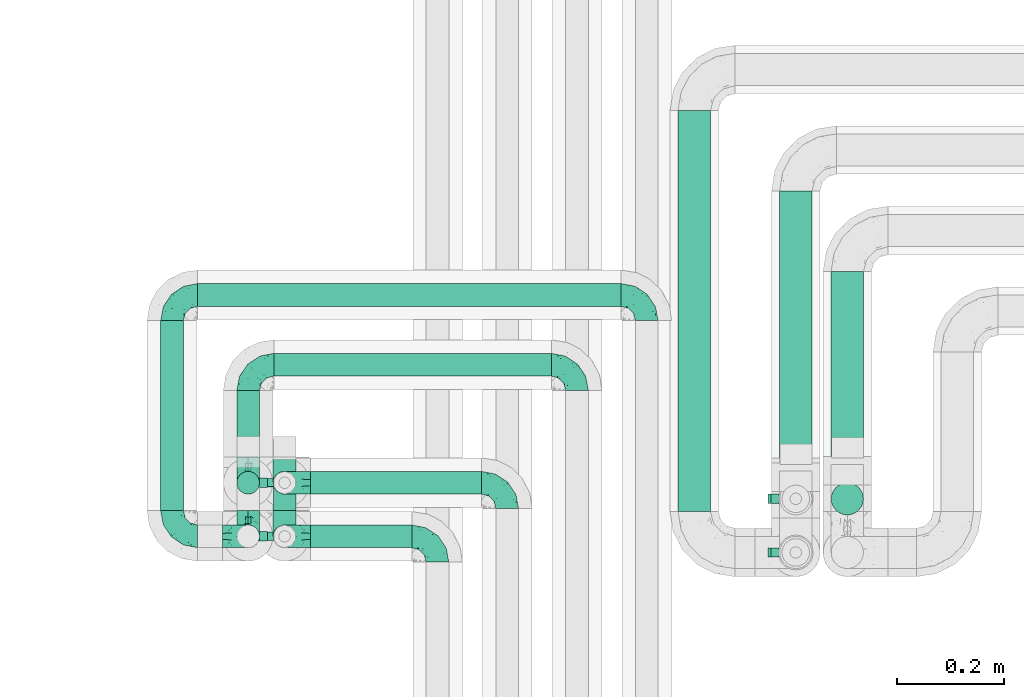
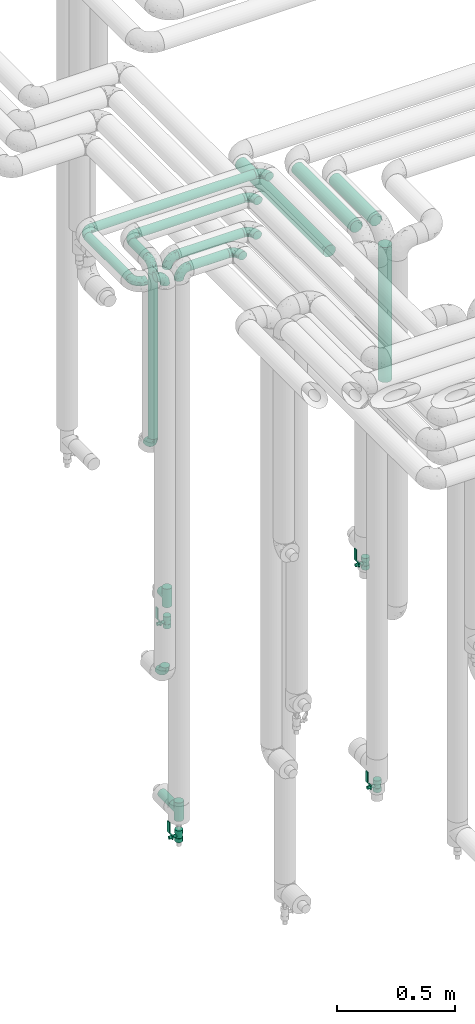
# One storey, part 632 of 827: 15 flow fittings, 12 flow segments, 4 flow controllers.
"""IFC2X3 building model written with IfcOpenShell, lengths in millimetres."""

from ifc_helpers import new_model, entity, si_unit, converted_unit, derived_unit, direction, frame, origin, origin_2d_with_axis, place, context, subcontext, project, spatial, polyline, circle, outline, extrude, faceted_brep, source, transform, mapped, material, material_list, type_object, type_shapes, element, save


model = new_model("IFC2X3")

# Units and contexts
model_context = context("Model", 3, precision=0.01, world=origin(), true_north=direction((6.12303176911189e-17, 1.0)))
body_context = subcontext(model_context, "Body", "Model", "MODEL_VIEW")
ifc_project = project(units=[si_unit("LENGTHUNIT", "METRE", prefix="MILLI"), si_unit("AREAUNIT", "SQUARE_METRE"), si_unit("VOLUMEUNIT", "CUBIC_METRE"), converted_unit("PLANEANGLEUNIT", "DEGREE", entity("IfcRatioMeasure", 0.0174532925199433), si_unit("PLANEANGLEUNIT", "RADIAN"), dimensions=[0, 0, 0, 0, 0, 0, 0]), si_unit("MASSUNIT", "GRAM", prefix="KILO"), derived_unit("MASSDENSITYUNIT", [(si_unit("MASSUNIT", "GRAM", prefix="KILO"), 1), (si_unit("LENGTHUNIT", "METRE"), -3)]), derived_unit("MOMENTOFINERTIAUNIT", [(si_unit("LENGTHUNIT", "METRE"), 4)]), si_unit("TIMEUNIT", "SECOND"), si_unit("FREQUENCYUNIT", "HERTZ"), si_unit("THERMODYNAMICTEMPERATUREUNIT", "DEGREE_CELSIUS"), derived_unit("THERMALTRANSMITTANCEUNIT", [(si_unit("MASSUNIT", "GRAM", prefix="KILO"), 1), (si_unit("THERMODYNAMICTEMPERATUREUNIT", "KELVIN"), -1), (si_unit("TIMEUNIT", "SECOND"), -3)]), derived_unit("VOLUMETRICFLOWRATEUNIT", [(si_unit("LENGTHUNIT", "METRE"), 3), (si_unit("TIMEUNIT", "SECOND"), -1)]), derived_unit("MASSFLOWRATEUNIT", [(si_unit("MASSUNIT", "GRAM", prefix="KILO"), 1), (si_unit("TIMEUNIT", "SECOND"), -1)]), derived_unit("ROTATIONALFREQUENCYUNIT", [(si_unit("TIMEUNIT", "SECOND"), -1)]), si_unit("ELECTRICCURRENTUNIT", "AMPERE"), si_unit("ELECTRICVOLTAGEUNIT", "VOLT"), si_unit("POWERUNIT", "WATT"), si_unit("FORCEUNIT", "NEWTON", prefix="KILO"), si_unit("ILLUMINANCEUNIT", "LUX"), si_unit("LUMINOUSFLUXUNIT", "LUMEN"), si_unit("LUMINOUSINTENSITYUNIT", "CANDELA"), derived_unit("USERDEFINED", [(si_unit("MASSUNIT", "GRAM", prefix="KILO"), -1), (si_unit("LENGTHUNIT", "METRE"), -2), (si_unit("TIMEUNIT", "SECOND"), 3), (si_unit("LUMINOUSFLUXUNIT", "LUMEN"), 1)]), derived_unit("LINEARVELOCITYUNIT", [(si_unit("LENGTHUNIT", "METRE"), 1), (si_unit("TIMEUNIT", "SECOND"), -1)]), si_unit("PRESSUREUNIT", "PASCAL"), derived_unit("USERDEFINED", [(si_unit("LENGTHUNIT", "METRE"), -2), (si_unit("MASSUNIT", "GRAM", prefix="KILO"), 1), (si_unit("TIMEUNIT", "SECOND"), -2)]), derived_unit("LINEARFORCEUNIT", [(si_unit("MASSUNIT", "GRAM", prefix="KILO"), 1), (si_unit("LENGTHUNIT", "METRE"), 1), (si_unit("TIMEUNIT", "SECOND"), -2), (si_unit("LENGTHUNIT", "METRE"), -1)]), derived_unit("PLANARFORCEUNIT", [(si_unit("MASSUNIT", "GRAM", prefix="KILO"), 1), (si_unit("LENGTHUNIT", "METRE"), 1), (si_unit("TIMEUNIT", "SECOND"), -2), (si_unit("LENGTHUNIT", "METRE"), -2)])], contexts=[model_context])

# Site, building, storey
site_placement = place(None, origin())
site = spatial("IfcSite", under=ifc_project, at=site_placement, CompositionType="ELEMENT")
building_placement = place(site_placement, origin())
building = spatial("IfcBuilding", under=site, at=building_placement, CompositionType="ELEMENT")
storey_placement = place(building_placement, frame((0.0, 0.0, 28200.0)))
storey = spatial("IfcBuildingStorey", under=building, at=storey_placement, Name="08", CompositionType="ELEMENT", Elevation=28200.0)

# Flow segments
pipe_segment_type = type_object("IfcPipeSegmentType", PredefinedType="NOTDEFINED")
flow_segment_1_placement = place(storey_placement, frame((30398.78, 15789.2, 3177.25)))
element("IfcFlowSegment", 1, at=flow_segment_1_placement, inside=storey, type_object=pipe_segment_type, context=body_context, shape_type="SweptSolid", body=[
    extrude(circle(Radius=21.15, at=origin_2d_with_axis()), frame((22.75, 0.0, 22.75), z_axis=(0.0, 1.0, 0.0), x_axis=(-1.0, 0.0, 0.0)), (0.0, 0.0, 1.0), 354.000000000015),
])
flow_segment_2_placement = place(storey_placement, frame((30540.78, 15889.2, 3177.25)))
element("IfcFlowSegment", 2, at=flow_segment_2_placement, inside=storey, type_object=pipe_segment_type, context=body_context, shape_type="SweptSolid", body=[
    extrude(circle(Radius=21.15, at=origin_2d_with_axis()), frame((22.75, 0.0, 22.75), z_axis=(0.0, 1.0, 0.0), x_axis=(-1.0, 0.0, 0.0)), (0.0, 0.0, 1.0), 124.000000000006),
])
flow_segment_3_placement = place(storey_placement, frame((30469.52, 16168.46, 3177.25)))
element("IfcFlowSegment", 3, at=flow_segment_3_placement, inside=storey, type_object=pipe_segment_type, context=body_context, shape_type="SweptSolid", body=[
    extrude(circle(Radius=21.15, at=origin_2d_with_axis()), frame((0.0, 22.75, 22.75), z_axis=(1.0, 0.0, 0.0), x_axis=(0.0, -1.0, 0.0)), (0.0, 0.0, 1.0), 788.99999999999),
])
flow_segment_4_placement = place(storey_placement, frame((30611.52, 16038.46, 3177.25)))
element("IfcFlowSegment", 4, at=flow_segment_4_placement, inside=storey, type_object=pipe_segment_type, context=body_context, shape_type="SweptSolid", body=[
    extrude(circle(Radius=21.15, at=origin_2d_with_axis()), frame((0.0, 22.75, 22.75), z_axis=(1.0, 0.0, 0.0), x_axis=(0.0, -1.0, 0.0)), (0.0, 0.0, 1.0), 516.999999999995),
])
flow_segment_5_placement = place(storey_placement, frame((30540.78, 15818.46, 2298.45)))
element("IfcFlowSegment", 5, at=flow_segment_5_placement, inside=storey, type_object=pipe_segment_type, context=body_context, shape_type="SweptSolid", body=[
    extrude(circle(Radius=21.15, at=origin_2d_with_axis()), frame((22.75, 22.75, 0.0)), (0.0, 0.0, 1.0), 853.55174000001),
])
flow_segment_6_placement = place(storey_placement, frame((30679.52, 15818.46, 3177.25)))
element("IfcFlowSegment", 6, at=flow_segment_6_placement, inside=storey, type_object=pipe_segment_type, context=body_context, shape_type="SweptSolid", body=[
    extrude(circle(Radius=21.15, at=origin_2d_with_axis()), frame((0.0, 22.75, 22.75), z_axis=(1.0, 0.0, 0.0), x_axis=(0.0, -1.0, 0.0)), (0.0, 0.0, 1.0), 318.999999999997),
])
flow_segment_7_placement = place(storey_placement, frame((30679.52, 15718.46, 3177.25)))
element("IfcFlowSegment", 7, at=flow_segment_7_placement, inside=storey, type_object=pipe_segment_type, context=body_context, shape_type="SweptSolid", body=[
    extrude(circle(Radius=21.15, at=origin_2d_with_axis()), frame((0.0, 22.75, 22.75), z_axis=(1.0, 0.0, 0.0), x_axis=(0.0, -1.0, 0.0)), (0.0, 0.0, 1.0), 188.999999999996),
])
flow_segment_8_placement = place(storey_placement, frame((30608.78, 15789.2, 384.75)))
element("IfcFlowSegment", 8, at=flow_segment_8_placement, inside=storey, type_object=pipe_segment_type, context=body_context, shape_type="SweptSolid", body=[
    extrude(circle(Radius=21.15, at=origin_2d_with_axis()), frame((22.75, 0.0, 22.75), z_axis=(0.0, 1.0, 0.0), x_axis=(1.0, 0.0, 0.0)), (0.0, 0.0, 1.0), 95.0000000000001),
])
flow_segment_9_placement = place(storey_placement, frame((31648.66, 15887.2, 2968.4)))
element("IfcFlowSegment", 9, at=flow_segment_9_placement, inside=storey, type_object=pipe_segment_type, context=body_context, shape_type="SweptSolid", body=[
    extrude(circle(Radius=30.0, at=origin_2d_with_axis()), frame((31.6, 0.0, 31.6), z_axis=(0.0, 1.0, 0.0), x_axis=(-1.0, 0.0, 0.0)), (0.0, 0.0, 1.0), 348.000000000016),
])
flow_segment_10_placement = place(storey_placement, frame((31552.66, 15887.2, 2968.4)))
element("IfcFlowSegment", 10, at=flow_segment_10_placement, inside=storey, type_object=pipe_segment_type, context=body_context, shape_type="SweptSolid", body=[
    extrude(circle(Radius=30.0, at=origin_2d_with_axis()), frame((31.6, 0.0, 31.6), z_axis=(0.0, 1.0, 0.0), x_axis=(-1.0, 0.0, 0.0)), (0.0, 0.0, 1.0), 498.000000000015),
])
flow_segment_11_placement = place(storey_placement, frame((31363.44, 15787.2, 2968.4)))
element("IfcFlowSegment", 11, at=flow_segment_11_placement, inside=storey, type_object=pipe_segment_type, context=body_context, shape_type="SweptSolid", body=[
    extrude(circle(Radius=30.0, at=origin_2d_with_axis()), frame((31.6, 0.0, 31.6), z_axis=(0.0, 1.0, 0.0), x_axis=(-1.0, 0.0, 0.0)), (0.0, 0.0, 1.0), 747.999990999931),
])
flow_segment_12_placement = place(storey_placement, frame((31648.66, 15779.61, 2226.0)))
element("IfcFlowSegment", 12, at=flow_segment_12_placement, inside=storey, type_object=pipe_segment_type, context=body_context, shape_type="SweptSolid", body=[
    extrude(circle(Radius=30.0, at=origin_2d_with_axis()), frame((31.6, 31.6, 0.0)), (0.0, 0.0, 1.0), 698.000000000006),
])

# Flow controllers
ifc_material = material()
ifc_material_list = material_list([ifc_material, ifc_material, ifc_material, ifc_material, ifc_material])
valve_type = type_object("IfcValveType", PredefinedType="NOTDEFINED", material=ifc_material_list)
shared_shape_1 = source(origin(), body_context, "Body", "SweptSolid", [
    extrude(circle(Radius=17.5, at=origin_2d_with_axis()), frame((-30.5, 0.0, 0.0), z_axis=(1.0, 0.0, 0.0), x_axis=(0.0, 1.0, 0.0)), (0.0, 0.0, 1.0), 20.3333333333333),
    extrude(circle(Radius=16.0, at=origin_2d_with_axis()), frame((-10.17, 0.0, 0.0), z_axis=(1.0, 0.0, 0.0), x_axis=(0.0, 1.0, 0.0)), (0.0, 0.0, 1.0), 20.3333333333333),
    extrude(circle(Radius=17.5, at=origin_2d_with_axis()), frame((10.17, 0.0, 0.0), z_axis=(1.0, 0.0, 0.0), x_axis=(0.0, 1.0, 0.0)), (0.0, 0.0, 1.0), 20.3333333333333),
    extrude(outline(polyline([(-38.75, -5.0), (-38.75, -10.0), (-17.92, -10.0), (2.08, 5.0), (56.25, 5.0), (56.25, 10.0), (0.42, 10.0), (-19.58, -5.0), (-38.75, -5.0)])), frame((28.75, -8.75, 41.5), z_axis=(0.0, -1.0, 0.0), x_axis=(1.0, 0.0, 0.0)), (0.0, 0.0, -1.0), 17.5),
    extrude(circle(Radius=8.0, at=origin_2d_with_axis()), origin(), (0.0, 0.0, 1.0), 49.0),
])
type_shapes(valve_type, [shared_shape_1])
for number, where, z_axis, x_axis in (
    (13, (31584.25, 15711.2, 221.0), (-1.0, 0.0, 0.0), (0.0, 0.0, 1.0)),
    (14, (31584.25, 15811.2, 1311.0), (-1.0, 0.0, 0.0), (0.0, 0.0, 1.0)),
    (15, (30631.52, 15841.2, 1323.0), (-1.0, 0.0, 0.0), (0.0, 0.0, 1.0)),
    (16, (30631.52, 15741.2, 278.0), (-1.0, 0.0, 0.0), (0.0, 0.0, 1.0)),
):
    element("IfcFlowController", number, at=place(storey_placement, frame(where, z_axis=z_axis, x_axis=x_axis)), inside=storey, type_object=valve_type, material=ifc_material, context=body_context, shape_type="MappedRepresentation", body=[
        mapped(shared_shape_1, transform((0.0, 0.0, 0.0), scale=1.0)),
    ])

# Flow fittings
pipe_fitting_type_1 = type_object("IfcPipeFittingType", Name="ADSK_1", PredefinedType="NOTDEFINED", material=ifc_material)
shared_shape_2 = source(origin(), body_context, "Body", "Brep", [
    faceted_brep([(-48.0, 10.6, -18.36), (-48.0, 5.49, -20.48), (-48.0, 0.0, -21.2), (-48.0, -5.49, -20.48), (-48.0, -10.6, -18.36), (-48.0, -14.99, -14.99), (-48.0, -18.36, -10.6), (-48.0, -20.48, -5.49), (-48.0, -21.2, 0.0), (-48.0, -20.48, 5.49), (-48.0, -18.36, 10.6), (-48.0, -14.99, 14.99), (-48.0, -10.6, 18.36), (-48.0, -5.49, 20.48), (-48.0, 0.0, 21.2), (-48.0, 5.49, 20.48), (-48.0, 10.6, 18.36), (-48.0, 14.99, 14.99), (-48.0, 18.36, 10.6), (-48.0, 20.48, 5.49), (-48.0, 21.2, 0.0), (-48.0, 20.48, -5.49), (-48.0, 18.36, -10.6), (-48.0, 14.99, -14.99), (0.0, 48.0, -21.2), (-5.49, 48.0, -20.48), (-10.6, 48.0, -18.36), (-14.99, 48.0, -14.99), (-18.36, 48.0, -10.6), (-20.48, 48.0, -5.49), (-21.2, 48.0, 0.0), (-20.48, 48.0, 5.49), (-18.36, 48.0, 10.6), (-14.99, 48.0, 14.99), (-10.6, 48.0, 18.36), (-5.49, 48.0, 20.48), (0.0, 48.0, 21.2), (5.49, 48.0, 20.48), (10.6, 48.0, 18.36), (14.99, 48.0, 14.99), (18.36, 48.0, 10.6), (20.48, 48.0, 5.49), (21.2, 48.0, 0.0), (20.48, 48.0, -5.49), (18.36, 48.0, -10.6), (14.99, 48.0, -14.99), (10.6, 48.0, -18.36), (5.49, 48.0, -20.48), (-35.25, -16.22, 12.01), (-34.76, -18.57, 0.0), (-20.87, -12.37, 10.9), (-31.49, -11.78, 15.9), (-37.0, -2.58, 20.86), (-33.89, 3.62, 21.15), (-31.81, -18.14, 6.76), (-5.78, 5.78, 17.67), (-19.42, -4.1, 17.86), (-9.6, -3.39, 13.73), (-35.44, -7.73, 19.13), (11.78, 31.49, 15.9), (-5.93, -5.46, 6.95), (-18.45, -13.78, 5.46), (-10.29, -8.43, 0.0), (-24.6, 0.55, 20.62), (-37.28, 17.94, 13.81), (-33.38, 22.85, 9.59), (-41.46, 20.06, 8.75), (-29.51, 20.45, 15.16), (-15.04, 10.79, 21.13), (-7.08, 16.98, 20.93), (-8.39, 23.51, 21.15), (-40.86, 13.03, 17.26), (-8.05, 41.26, 19.83), (-3.21, 35.97, 21.14), (8.53, 19.66, 14.74), (4.1, 19.42, 17.86), (-37.72, 22.66, 4.78), (-37.07, 8.58, 19.98), (-13.0, 5.43, 19.97), (-3.78, 13.93, 19.7), (3.02, 8.69, 13.43), (-2.27, -0.05, 10.65), (6.22, 6.99, 7.09), (-22.25, 34.6, 9.45), (18.14, 31.81, 6.76), (16.22, 35.25, 12.01), (12.37, 20.87, 10.9), (7.73, 35.44, 19.13), (-21.52, -15.93, 0.0), (2.58, 37.0, 20.86), (18.57, 34.76, 0.0), (13.78, 18.45, 5.46), (15.93, 21.52, 0.0), (-20.03, -8.54, 14.9), (-28.6, 28.6, 5.16), (-24.79, 34.6, 0.0), (-34.6, 24.79, 0.0), (-22.81, 37.41, 4.68), (-23.36, 26.33, 14.79), (-13.68, 37.05, 17.49), (-17.72, 38.12, 13.73), (-26.25, 27.3, 11.24), (-9.71, 32.34, 20.14), (-17.26, 25.6, 18.71), (-26.33, 9.99, 20.77), (-24.06, 6.05, 21.2), (-25.02, 15.46, 19.56), (-24.3, 20.72, 17.57), (-31.95, 15.23, 17.8), (-13.53, 24.7, 20.21), (-17.6, 17.6, 20.6), (-0.55, 24.6, 20.62), (-11.41, -7.48, 10.43), (0.93, -0.93, 0.0), (8.43, 10.29, 0.0), (-11.41, -7.48, -10.43), (-20.1, -8.84, -14.66), (-9.6, -3.39, -13.73), (7.73, 35.44, -19.13), (4.1, 19.42, -17.86), (-0.55, 24.6, -20.62), (-38.12, 17.72, -13.73), (-37.05, 13.68, -17.49), (-32.34, 9.71, -20.14), (-41.26, 8.05, -19.83), (-37.41, 22.81, -4.68), (-23.51, 8.39, -21.15), (-35.97, 3.21, -21.14), (-28.6, 28.6, -5.16), (-31.81, -18.14, -6.76), (-18.45, -13.78, -5.46), (-25.6, 17.26, -18.71), (-19.42, -4.1, -17.86), (-17.94, 37.28, -13.81), (-22.85, 33.38, -9.59), (-20.06, 41.46, -8.75), (-31.49, -11.78, -15.9), (-35.25, -16.22, -12.01), (8.53, 19.66, -14.74), (11.78, 31.49, -15.9), (-9.99, 26.33, -20.77), (-6.05, 24.06, -21.2), (-10.79, 15.04, -21.13), (-37.0, -2.58, -20.86), (-16.98, 7.08, -20.93), (-5.43, 13.0, -19.97), (-13.93, 3.78, -19.7), (-20.87, -12.37, -10.9), (-26.33, 23.36, -14.79), (-22.66, 37.72, -4.78), (13.78, 18.45, -5.46), (18.14, 31.81, -6.76), (-15.46, 25.02, -19.56), (-20.72, 24.3, -17.57), (16.22, 35.25, -12.01), (-13.03, 40.86, -17.26), (-8.58, 37.07, -19.98), (2.58, 37.0, -20.86), (-3.62, 33.89, -21.15), (-34.6, 22.25, -9.45), (6.22, 6.99, -7.09), (-20.45, 29.51, -15.16), (-35.44, -7.73, -19.13), (12.37, 20.87, -10.9), (-27.3, 26.25, -11.24), (-15.23, 31.95, -17.8), (-24.7, 13.53, -20.21), (-24.6, 0.55, -20.62), (-5.78, 5.78, -17.67), (-17.6, 17.6, -20.6), (3.02, 8.69, -13.43), (-5.93, -5.46, -6.95), (-2.27, -0.05, -10.65)], [[[0, 1, 2, 3, 4, 5, 6, 7, 8, 9, 10, 11, 12, 13, 14, 15, 16, 17, 18, 19, 20, 21, 22, 23]], [[24, 25, 26, 27, 28, 29, 30, 31, 32, 33, 34, 35, 36, 37, 38, 39, 40, 41, 42, 43, 44, 45, 46, 47]], [[10, 48, 11]], [[9, 8, 49]], [[48, 50, 51]], [[14, 52, 53]], [[10, 54, 48]], [[9, 54, 10]], [[55, 56, 57]], [[51, 12, 11]], [[51, 58, 12]], [[59, 39, 38]], [[60, 61, 62]], [[58, 56, 63]], [[64, 65, 66]], [[67, 65, 64]], [[68, 69, 70]], [[16, 71, 17]], [[13, 52, 14]], [[35, 72, 73]], [[14, 53, 15]], [[17, 64, 18]], [[74, 59, 75]], [[20, 19, 76]], [[66, 19, 18]], [[77, 15, 53]], [[15, 77, 16]], [[69, 78, 79]], [[80, 81, 82]], [[32, 31, 83]], [[84, 85, 86]], [[59, 87, 75]], [[61, 54, 88]], [[36, 89, 37]], [[84, 41, 40]], [[36, 35, 73]], [[90, 41, 84]], [[40, 39, 85]], [[12, 58, 13]], [[85, 84, 40]], [[91, 84, 86]], [[84, 92, 90]], [[87, 38, 37]], [[93, 56, 51]], [[65, 94, 76]], [[94, 95, 96]], [[84, 91, 92]], [[95, 97, 30]], [[98, 99, 100]], [[76, 94, 96]], [[101, 98, 83]], [[100, 99, 33]], [[102, 70, 73]], [[103, 102, 99]], [[94, 97, 95]], [[72, 99, 102]], [[72, 35, 34]], [[34, 33, 99]], [[9, 49, 54]], [[87, 59, 38]], [[104, 105, 68]], [[106, 103, 107]], [[106, 77, 104]], [[71, 64, 17]], [[108, 107, 67]], [[33, 32, 100]], [[109, 103, 110]], [[102, 109, 70]], [[89, 73, 111]], [[50, 48, 54]], [[51, 11, 48]], [[56, 58, 51]], [[88, 54, 49]], [[52, 58, 63]], [[50, 112, 93]], [[56, 55, 78]], [[39, 59, 85]], [[86, 85, 59]], [[89, 87, 37]], [[42, 41, 90]], [[111, 79, 75]], [[111, 75, 87]], [[75, 55, 80]], [[104, 77, 53]], [[71, 77, 108]], [[32, 83, 100]], [[98, 100, 83]], [[99, 98, 103]], [[106, 107, 108]], [[68, 70, 110]], [[111, 73, 70]], [[68, 110, 104]], [[68, 63, 78]], [[57, 93, 112]], [[80, 55, 57]], [[61, 50, 54]], [[80, 82, 86]], [[81, 57, 112]], [[74, 86, 59]], [[60, 113, 82]], [[82, 114, 91]], [[101, 94, 65]], [[97, 94, 83]], [[73, 89, 36]], [[87, 89, 111]], [[58, 52, 13]], [[53, 52, 63]], [[104, 53, 105]], [[106, 104, 110]], [[20, 76, 96]], [[76, 19, 66]], [[103, 106, 110]], [[77, 106, 108]], [[103, 98, 107]], [[67, 107, 98]], [[67, 98, 101]], [[108, 67, 64]], [[53, 63, 105]], [[63, 68, 105]], [[83, 31, 97]], [[30, 97, 31]], [[62, 113, 60]], [[112, 61, 60]], [[61, 88, 62]], [[86, 82, 91]], [[56, 78, 63]], [[114, 82, 113]], [[114, 92, 91]], [[79, 78, 55]], [[75, 79, 55]], [[69, 79, 111]], [[70, 69, 111]], [[78, 69, 68]], [[77, 71, 16]], [[64, 71, 108]], [[64, 66, 18]], [[76, 66, 65]], [[99, 72, 34]], [[73, 72, 102]], [[94, 101, 83]], [[67, 101, 65]], [[75, 80, 74]], [[80, 86, 74]], [[70, 109, 110]], [[102, 103, 109]], [[50, 93, 51]], [[57, 56, 93]], [[61, 112, 50]], [[81, 112, 60]], [[82, 81, 60]], [[80, 57, 81]], [[115, 116, 117]], [[118, 119, 120]], [[121, 122, 23]], [[123, 124, 122]], [[96, 125, 20]], [[123, 126, 127]], [[128, 96, 95]], [[129, 130, 88]], [[123, 122, 131]], [[116, 132, 117]], [[133, 134, 135]], [[0, 124, 1]], [[5, 136, 137]], [[138, 119, 139]], [[129, 88, 49]], [[140, 141, 142]], [[6, 5, 137]], [[46, 118, 47]], [[143, 3, 2]], [[144, 145, 146]], [[6, 129, 7]], [[129, 137, 147]], [[127, 2, 1]], [[148, 122, 121]], [[128, 125, 96]], [[134, 128, 149]], [[95, 149, 128]], [[150, 151, 92]], [[30, 29, 149]], [[152, 131, 153]], [[27, 133, 28]], [[154, 45, 44]], [[136, 5, 4]], [[27, 26, 155]], [[156, 26, 25]], [[24, 157, 158]], [[24, 47, 157]], [[22, 21, 159]], [[160, 150, 114]], [[134, 133, 161]], [[142, 144, 126]], [[46, 139, 118]], [[162, 136, 4]], [[156, 25, 158]], [[1, 124, 127]], [[115, 147, 116]], [[45, 154, 139]], [[139, 46, 45]], [[154, 163, 139]], [[162, 4, 3]], [[42, 90, 43]], [[130, 129, 147]], [[49, 7, 129]], [[43, 151, 44]], [[0, 23, 122]], [[24, 158, 25]], [[136, 162, 132]], [[135, 29, 28]], [[43, 90, 151]], [[164, 148, 159]], [[152, 156, 140]], [[155, 133, 27]], [[165, 153, 161]], [[23, 22, 121]], [[123, 131, 166]], [[123, 166, 126]], [[143, 127, 167]], [[147, 137, 136]], [[8, 7, 49]], [[129, 6, 137]], [[143, 162, 3]], [[167, 146, 132]], [[167, 132, 162]], [[132, 168, 117]], [[44, 151, 154]], [[92, 151, 90]], [[163, 154, 151]], [[119, 118, 139]], [[157, 118, 120]], [[138, 139, 163]], [[119, 168, 145]], [[140, 156, 158]], [[155, 156, 165]], [[22, 159, 121]], [[148, 121, 159]], [[122, 148, 131]], [[152, 153, 165]], [[142, 126, 169]], [[167, 127, 126]], [[142, 169, 140]], [[142, 120, 145]], [[168, 170, 117]], [[160, 171, 172]], [[115, 172, 171]], [[171, 62, 130]], [[119, 170, 168]], [[170, 163, 160]], [[150, 163, 151]], [[113, 171, 160]], [[164, 128, 134]], [[125, 128, 159]], [[127, 143, 2]], [[162, 143, 167]], [[118, 157, 47]], [[158, 157, 120]], [[140, 158, 141]], [[152, 140, 169]], [[30, 149, 95]], [[149, 29, 135]], [[131, 152, 169]], [[156, 152, 165]], [[131, 148, 153]], [[161, 153, 148]], [[161, 148, 164]], [[165, 161, 133]], [[158, 120, 141]], [[120, 142, 141]], [[159, 21, 125]], [[20, 125, 21]], [[115, 130, 147]], [[114, 113, 160]], [[62, 171, 113]], [[62, 88, 130]], [[160, 163, 150]], [[150, 92, 114]], [[119, 145, 120]], [[146, 145, 168]], [[132, 146, 168]], [[144, 146, 167]], [[126, 144, 167]], [[145, 144, 142]], [[156, 155, 26]], [[133, 155, 165]], [[133, 135, 28]], [[149, 135, 134]], [[122, 124, 0]], [[127, 124, 123]], [[128, 164, 159]], [[161, 164, 134]], [[163, 170, 138]], [[170, 119, 138]], [[131, 169, 166]], [[126, 166, 169]], [[147, 136, 116]], [[132, 116, 136]], [[172, 115, 117]], [[130, 115, 171]], [[117, 170, 172]], [[160, 172, 170]]]),
])
type_shapes(pipe_fitting_type_1, [shared_shape_2])
for number, where, z_axis, x_axis, name in (
    (17, (30421.52, 15741.2, 3200.0), (0.0, 0.0, 1.0), (0.0, -1.0, 0.0), "ADSK_1"),
    (18, (30563.52, 16061.2, 3200.0), (0.0, 0.0, 1.0), (-1.0, 0.0, 0.0), "ADSK_1"),
    (19, (30421.52, 16191.2, 3200.0), (0.0, 0.0, 1.0), (-1.0, 0.0, 0.0), "ADSK_1"),
    (20, (30563.52, 15841.2, 3200.0), (1.0, 0.0, 0.0), (0.0, -1.0, 0.0), "ADSK_1"),
    (21, (30563.52, 15841.2, 2250.45), (1.0, 0.0, 0.0), (0.0, 0.0, -1.0), "ADSK_1"),
    (22, (30916.52, 15741.2, 3200.0), (0.0, 0.0, 1.0), (0.0, 1.0, 0.0), "ADSK_1"),
    (23, (31046.52, 15841.2, 3200.0), (0.0, 0.0, 1.0), (0.0, 1.0, 0.0), "ADSK_1"),
    (24, (31176.52, 16061.2, 3200.0), (0.0, 0.0, 1.0), (0.0, 1.0, 0.0), "ADSK_1"),
    (25, (31306.52, 16191.2, 3200.0), (0.0, 0.0, 1.0), (0.0, 1.0, 0.0), "ADSK_1"),
    (26, (30563.52, 15741.2, 3200.0), (0.0, 1.0, 0.0), (1.0, 0.0, 0.0), "ADSK_1"),
    (27, (30563.52, 15741.2, 1130.45), (1.0, 0.0, 0.0), (0.0, 0.0, -1.0), "ADSK_1"),
    (28, (30631.52, 15841.2, 3200.0), (0.0, -1.0, 0.0), (-1.0, 0.0, 0.0), "ADSK_1"),
    (29, (30631.52, 15741.2, 3200.0), (0.0, -1.0, 0.0), (-1.0, 0.0, 0.0), "ADSK_1"),
):
    element("IfcFlowFitting", number, at=place(storey_placement, frame(where, z_axis=z_axis, x_axis=x_axis)), inside=storey, type_object=pipe_fitting_type_1, material=ifc_material, Name=name, ObjectType="ADSK_1", context=body_context, shape_type="MappedRepresentation", body=[
        mapped(shared_shape_2, transform((0.0, 0.0, 0.0), scale=1.0)),
    ])
pipe_fitting_type_2 = type_object("IfcPipeFittingType", Name="ADSK_1", PredefinedType="NOTDEFINED", material=ifc_material)
shared_shape_3 = source(origin(), body_context, "Body", "Brep", [
    faceted_brep([(-48.0, 10.6, -18.36), (-48.0, 5.49, -20.48), (-48.0, 0.0, -21.2), (-48.0, -5.49, -20.48), (-48.0, -10.6, -18.36), (-48.0, -14.99, -14.99), (-48.0, -18.36, -10.6), (-48.0, -20.48, -5.49), (-48.0, -21.2, 0.0), (-48.0, -20.48, 5.49), (-48.0, -18.36, 10.6), (-48.0, -14.99, 14.99), (-48.0, -10.6, 18.36), (-48.0, -5.49, 20.48), (-48.0, 0.0, 21.2), (-48.0, 5.49, 20.48), (-48.0, 10.6, 18.36), (-48.0, 14.99, 14.99), (-48.0, 18.36, 10.6), (-48.0, 20.48, 5.49), (-48.0, 21.2, 0.0), (-48.0, 20.48, -5.49), (-48.0, 18.36, -10.6), (-48.0, 14.99, -14.99), (48.0, 0.0, -21.2), (48.0, 5.49, -20.48), (48.0, 10.6, -18.36), (48.0, 14.99, -14.99), (48.0, 18.36, -10.6), (48.0, 20.48, -5.49), (48.0, 21.2, 0.0), (48.0, 20.48, 5.49), (48.0, 18.36, 10.6), (48.0, 14.99, 14.99), (48.0, 10.6, 18.36), (48.0, 5.49, 20.48), (48.0, 0.0, 21.2), (48.0, -5.49, 20.48), (48.0, -10.6, 18.36), (48.0, -14.99, 14.99), (48.0, -18.36, 10.6), (48.0, -20.48, 5.49), (48.0, -21.2, 0.0), (48.0, -20.48, -5.49), (48.0, -18.36, -10.6), (48.0, -14.99, -14.99), (48.0, -10.6, -18.36), (48.0, -5.49, -20.48), (20.43, -20.43, 5.66), (21.2, -21.2, 0.0), (-21.2, -21.2, 0.0), (18.35, -18.35, 10.62), (11.88, -11.88, 17.56), (15.38, -15.38, 14.59), (-20.43, -20.43, 5.66), (-18.35, -18.35, 10.62), (-15.38, -15.38, 14.59), (-11.88, -11.88, 17.56), (-8.06, -8.06, 19.61), (8.06, -8.06, 19.61), (4.07, -4.07, 20.81), (0.0, 0.0, 21.2), (-4.07, -4.07, 20.81), (4.07, -4.07, -20.81), (0.0, 0.0, -21.2), (-4.07, -4.07, -20.81), (-8.06, -8.06, -19.61), (8.06, -8.06, -19.61), (11.88, -11.88, -17.56), (15.38, -15.38, -14.59), (18.35, -18.35, -10.62), (20.43, -20.43, -5.66), (-11.88, -11.88, -17.56), (-15.38, -15.38, -14.59), (-20.43, -20.43, -5.66), (-18.35, -18.35, -10.62), (0.0, -48.0, -21.2), (5.49, -48.0, -20.48), (10.6, -48.0, -18.36), (14.99, -48.0, -14.99), (18.36, -48.0, -10.6), (20.48, -48.0, -5.49), (21.2, -48.0, 0.0), (20.48, -48.0, 5.49), (18.36, -48.0, 10.6), (14.99, -48.0, 14.99), (10.6, -48.0, 18.36), (5.49, -48.0, 20.48), (0.0, -48.0, 21.2), (-5.49, -48.0, 20.48), (-10.6, -48.0, 18.36), (-14.99, -48.0, 14.99), (-18.36, -48.0, 10.6), (-20.48, -48.0, 5.49), (-21.2, -48.0, 0.0), (-20.48, -48.0, -5.49), (-18.36, -48.0, -10.6), (-14.99, -48.0, -14.99), (-10.6, -48.0, -18.36), (-5.49, -48.0, -20.48)], [[[0, 1, 2, 3, 4, 5, 6, 7, 8, 9, 10, 11, 12, 13, 14, 15, 16, 17, 18, 19, 20, 21, 22, 23]], [[24, 25, 26, 27, 28, 29, 30, 31, 32, 33, 34, 35, 36, 37, 38, 39, 40, 41, 42, 43, 44, 45, 46, 47]], [[41, 40, 48]], [[42, 41, 49]], [[50, 9, 8]], [[49, 41, 48]], [[40, 51, 48]], [[39, 38, 52]], [[51, 40, 53]], [[52, 53, 39]], [[53, 40, 39]], [[50, 54, 9]], [[9, 54, 10]], [[54, 55, 10]], [[56, 57, 11]], [[11, 10, 56]], [[11, 57, 12]], [[56, 10, 55]], [[12, 57, 58]], [[52, 38, 59]], [[60, 36, 61]], [[62, 61, 14]], [[59, 37, 60]], [[37, 59, 38]], [[60, 37, 36]], [[61, 36, 35, 15, 14]], [[32, 31, 19, 18]], [[17, 16, 34, 33]], [[18, 17, 33, 32]], [[35, 34, 16, 15]], [[20, 19, 31, 30]], [[62, 13, 58]], [[13, 62, 14]], [[58, 13, 12]], [[27, 23, 22, 28]], [[22, 21, 29, 28]], [[0, 23, 27, 26]], [[20, 30, 29, 21]], [[24, 47, 63]], [[24, 64, 2, 1, 25]], [[64, 24, 63]], [[2, 64, 65]], [[26, 25, 1, 0]], [[65, 66, 3]], [[2, 65, 3]], [[66, 4, 3]], [[63, 47, 67]], [[46, 45, 68]], [[69, 68, 45]], [[44, 70, 69]], [[69, 45, 44]], [[46, 68, 67]], [[43, 42, 49]], [[7, 50, 8]], [[43, 71, 44]], [[71, 43, 49]], [[44, 71, 70]], [[72, 4, 66]], [[72, 5, 4]], [[5, 72, 73]], [[5, 73, 6]], [[74, 50, 7]], [[75, 74, 6]], [[74, 7, 6]], [[75, 6, 73]], [[46, 67, 47]], [[76, 77, 78, 79, 80, 81, 82, 83, 84, 85, 86, 87, 88, 89, 90, 91, 92, 93, 94, 95, 96, 97, 98, 99]], [[50, 94, 93]], [[54, 50, 93]], [[91, 90, 57]], [[56, 92, 91]], [[54, 93, 92]], [[58, 90, 89]], [[55, 54, 92]], [[56, 55, 92]], [[58, 57, 90]], [[88, 61, 62]], [[58, 89, 62]], [[56, 91, 57]], [[62, 89, 88]], [[60, 88, 87]], [[86, 59, 87]], [[84, 83, 48]], [[53, 85, 84]], [[52, 86, 85]], [[49, 83, 82]], [[59, 60, 87]], [[52, 59, 86]], [[49, 48, 83]], [[51, 53, 84]], [[48, 51, 84]], [[52, 85, 53]], [[88, 60, 61]], [[82, 81, 49]], [[71, 49, 81]], [[69, 80, 79]], [[79, 78, 68]], [[71, 81, 80]], [[67, 78, 77]], [[70, 71, 80]], [[69, 70, 80]], [[67, 68, 78]], [[76, 64, 63]], [[67, 77, 63]], [[69, 79, 68]], [[63, 77, 76]], [[65, 76, 99]], [[98, 66, 99]], [[96, 95, 74]], [[73, 97, 96]], [[72, 98, 97]], [[50, 95, 94]], [[66, 65, 99]], [[72, 66, 98]], [[50, 74, 95]], [[75, 73, 96]], [[74, 75, 96]], [[72, 97, 73]], [[76, 65, 64]]]),
])
type_shapes(pipe_fitting_type_2, [shared_shape_3])
for number, where, z_axis, x_axis, name in (
    (30, (30631.52, 15841.2, 1452.5), (-1.0, 0.0, 0.0), (0.0, 0.0, -1.0), "ADSK_1"),
    (31, (30631.52, 15741.2, 407.5), (-1.0, 0.0, 0.0), (0.0, 0.0, -1.0), "ADSK_1"),
):
    element("IfcFlowFitting", number, at=place(storey_placement, frame(where, z_axis=z_axis, x_axis=x_axis)), inside=storey, type_object=pipe_fitting_type_2, material=ifc_material, Name=name, ObjectType="ADSK_1", context=body_context, shape_type="MappedRepresentation", body=[
        mapped(shared_shape_3, transform((0.0, 0.0, 0.0), scale=1.0)),
    ])

save(model, "model.ifc")
